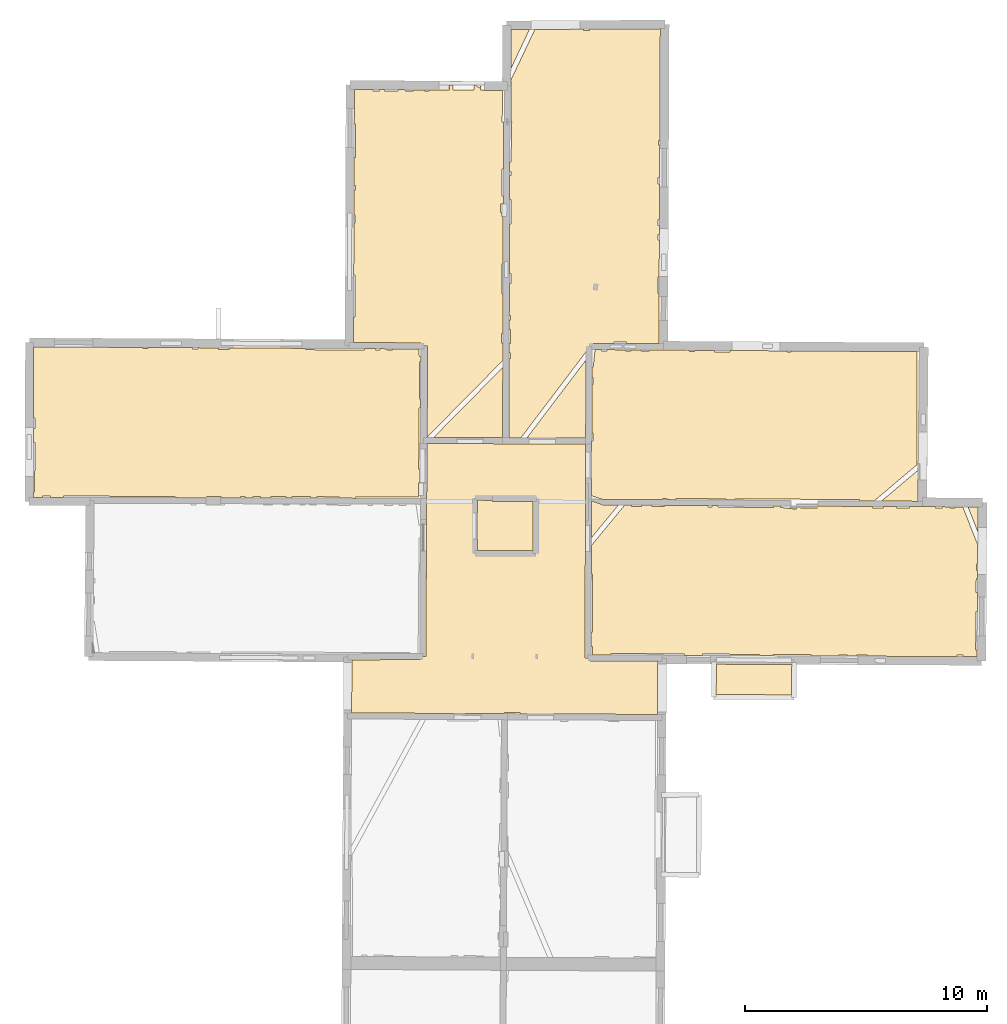
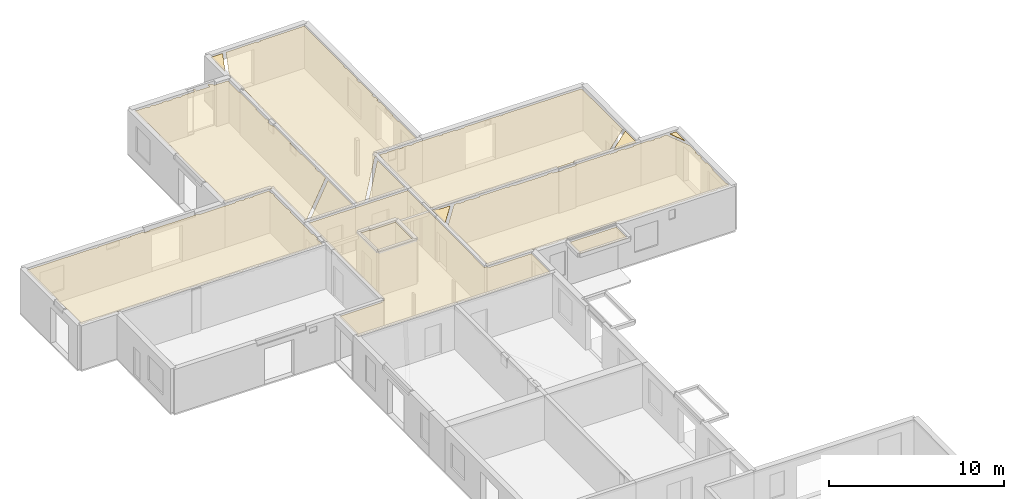
# One storey, part 13 of 15: 14 coverings.
"""IFC2X3 building model written with IfcOpenShell, lengths in metres."""

from ifc_helpers import new_model, entity, si_unit, converted_unit, derived_unit, direction, frame, origin, origin_with_axes, place, context, subcontext, project, spatial, polyline, outline, extrude, material, layer, layer_set, layer_usage, type_object, element, save


model = new_model("IFC2X3")

# Units and contexts
model_context = context("Model", 3, precision=1e-05, world=origin(), true_north=direction((0.0, 1.0)))
body_context = subcontext(model_context, "Body", "Model", "MODEL_VIEW")
ifc_project = project(units=[si_unit("LENGTHUNIT", "METRE"), si_unit("AREAUNIT", "SQUARE_METRE"), si_unit("VOLUMEUNIT", "CUBIC_METRE"), converted_unit("PLANEANGLEUNIT", "DEGREE", entity("IfcRatioMeasure", 0.0174532925199433), si_unit("PLANEANGLEUNIT", "RADIAN"), dimensions=[0, 0, 0, 0, 0, 0, 0]), si_unit("MASSUNIT", "GRAM", prefix="KILO"), derived_unit("MASSDENSITYUNIT", [(si_unit("MASSUNIT", "GRAM", prefix="KILO"), 1), (si_unit("LENGTHUNIT", "METRE"), -3)]), derived_unit("MOMENTOFINERTIAUNIT", [(si_unit("LENGTHUNIT", "METRE"), 4)]), si_unit("TIMEUNIT", "SECOND"), si_unit("FREQUENCYUNIT", "HERTZ"), si_unit("THERMODYNAMICTEMPERATUREUNIT", "DEGREE_CELSIUS"), derived_unit("THERMALTRANSMITTANCEUNIT", [(si_unit("MASSUNIT", "GRAM", prefix="KILO"), 1), (si_unit("THERMODYNAMICTEMPERATUREUNIT", "KELVIN"), -1), (si_unit("TIMEUNIT", "SECOND"), -3)]), derived_unit("VOLUMETRICFLOWRATEUNIT", [(si_unit("LENGTHUNIT", "METRE"), 3), (si_unit("TIMEUNIT", "SECOND"), -1)]), si_unit("ELECTRICCURRENTUNIT", "AMPERE"), si_unit("ELECTRICVOLTAGEUNIT", "VOLT"), si_unit("POWERUNIT", "WATT"), si_unit("FORCEUNIT", "NEWTON", prefix="KILO"), si_unit("ILLUMINANCEUNIT", "LUX"), si_unit("LUMINOUSFLUXUNIT", "LUMEN"), si_unit("LUMINOUSINTENSITYUNIT", "CANDELA"), derived_unit("USERDEFINED", [(si_unit("MASSUNIT", "GRAM", prefix="KILO"), -1), (si_unit("LENGTHUNIT", "METRE"), -2), (si_unit("TIMEUNIT", "SECOND"), 3), (si_unit("LUMINOUSFLUXUNIT", "LUMEN"), 1)]), derived_unit("LINEARVELOCITYUNIT", [(si_unit("LENGTHUNIT", "METRE"), 1), (si_unit("TIMEUNIT", "SECOND"), -1)]), si_unit("PRESSUREUNIT", "PASCAL"), derived_unit("USERDEFINED", [(si_unit("LENGTHUNIT", "METRE"), -2), (si_unit("MASSUNIT", "GRAM", prefix="KILO"), 1), (si_unit("TIMEUNIT", "SECOND"), -2)]), derived_unit("LINEARFORCEUNIT", [(si_unit("MASSUNIT", "GRAM", prefix="KILO"), 1), (si_unit("LENGTHUNIT", "METRE"), 1), (si_unit("TIMEUNIT", "SECOND"), -2), (si_unit("LENGTHUNIT", "METRE"), -1)]), derived_unit("PLANARFORCEUNIT", [(si_unit("MASSUNIT", "GRAM", prefix="KILO"), 1), (si_unit("LENGTHUNIT", "METRE"), 1), (si_unit("TIMEUNIT", "SECOND"), -2), (si_unit("LENGTHUNIT", "METRE"), -2)])], contexts=[model_context])

# Site, building, storey
placement = place(None, origin())
site = spatial("IfcSite", under=ifc_project, at=placement, CompositionType="ELEMENT")
building = spatial("IfcBuilding", under=site, at=placement, CompositionType="ELEMENT")
storey_placement = place(placement, frame((0.0, 0.0, 2.3807327747345)))
storey = spatial("IfcBuildingStorey", under=building, at=storey_placement, Name="Level 2", CompositionType="ELEMENT", Elevation=2.3807327747345)

# Coverings
ifc_material = material(Name="Covering default")
ifc_layer_1 = layer(ifc_material, 0.02)
ifc_layer_set_1 = layer_set([ifc_layer_1], Name="Covering : 20mm")
ifc_layer_usage_1 = layer_usage(ifc_layer_set_1, "AXIS3", "POSITIVE", 0.0)
covering_type_1 = type_object("IfcCoveringType", Name="Covering : 20mm", PredefinedType="CEILING")
covering_1_placement = place(placement, frame((0.0, 0.0, 5.31589412689209)))
element("IfcCovering", 1, at=covering_1_placement, inside=storey, type_object=covering_type_1, material=ifc_layer_usage_1, Name="Covering : 20mm", ObjectType="Covering : 20mm", PredefinedType="CEILING", context=body_context, shape_type="SweptSolid", body=[
    extrude(outline(polyline([(0.0212154388427734, 51.1030578613281), (2.85214328765869, 51.1116523742676), (2.85176181793213, 51.2374305725098), (3.07087993621826, 51.2362594604492), (3.12139987945557, 60.0334701538086), (6.24017238616943, 60.0231819152832), (9.67142772674561, 60.0118675231934), (9.64021587371826, 51.1887435913086), (9.84285259246826, 51.1880264282227), (9.84205532073975, 51.062816619873), (12.6475248336792, 51.0449867248535), (12.6377820968628, 48.8478355407715), (6.95900249481201, 48.876148223877), (6.95909786224365, 48.932804107666), (6.31617641448975, 48.9338722229004), (6.31608486175537, 48.8793563842773), (0.00825309753417969, 48.9108047485352), (0.0212154388427734, 51.1030578613281)])), origin_with_axes(), (0.0, 0.0, 1.0), 0.02),
])
ifc_layer_2 = layer(ifc_material, 0.02)
ifc_layer_set_2 = layer_set([ifc_layer_2], Name="Covering : 20mm")
ifc_layer_usage_2 = layer_usage(ifc_layer_set_2, "AXIS3", "POSITIVE", 0.0)
covering_type_2 = type_object("IfcCoveringType", Name="Covering : 20mm", PredefinedType="CEILING")
covering_2_placement = place(placement, frame((0.0, 0.0, 5.31589412689209)))
element("IfcCovering", 2, at=covering_2_placement, inside=storey, type_object=covering_type_2, material=ifc_layer_usage_2, Name="Covering : 20mm", ObjectType="Covering : 20mm", PredefinedType="CEILING", context=body_context, shape_type="SweptSolid", body=[
    extrude(outline(polyline([(15.0728063583374, 50.9225845336914), (18.1801872253418, 50.908634185791), (18.170539855957, 49.6549987792969), (15.0572061538696, 49.673583984375), (15.0728063583374, 50.9225845336914)])), origin_with_axes(), (0.0, 0.0, 1.0), 0.02),
])
ifc_layer_3 = layer(ifc_material, 0.02)
ifc_layer_set_3 = layer_set([ifc_layer_3], Name="Covering : 20mm")
ifc_layer_usage_3 = layer_usage(ifc_layer_set_3, "AXIS3", "POSITIVE", 0.0)
covering_type_3 = type_object("IfcCoveringType", Name="Covering : 20mm", PredefinedType="CEILING")
covering_3_placement = place(placement, frame((0.0, 0.0, 5.31589412689209)))
element("IfcCovering", 3, at=covering_3_placement, inside=storey, type_object=covering_type_3, material=ifc_layer_usage_3, Name="Covering : 20mm", ObjectType="Covering : 20mm", PredefinedType="CEILING", context=body_context, shape_type="SweptSolid", body=[
    extrude(outline(polyline([(9.89396572113037, 52.2481384277344), (9.94461345672607, 52.2478446960449), (9.95860576629639, 54.6478233337402), (9.90245532989502, 54.6481513977051), (9.90660762786865, 55.8220672607422), (11.2822408676147, 57.495304107666), (11.56334400177, 57.4933929443359), (11.5632467269897, 57.4351577758789), (11.9732465744019, 57.4344787597656), (11.9733400344849, 57.490608215332), (12.4133367538452, 57.4876174926758), (12.4132452011108, 57.4337463378906), (12.923243522644, 57.4328956604004), (12.9233293533325, 57.4841537475586), (14.7133131027222, 57.4719886779785), (14.7132253646851, 57.4199180603027), (14.8932256698608, 57.4196166992188), (14.8933115005493, 57.4707641601562), (15.1435708999634, 57.4690628051758), (15.1432085037231, 57.4092025756836), (17.4231910705566, 57.3954086303711), (17.4235420227051, 57.4535713195801), (17.7192878723145, 57.4515609741211), (17.7131881713867, 57.3949279785156), (18.3730697631836, 57.3238296508789), (18.3794288635254, 57.3828544616699), (19.2521591186523, 57.3787498474121), (19.2524909973145, 57.4487533569336), (21.5166397094727, 57.4381141662598), (21.5165405273438, 57.378604888916), (21.9631652832031, 57.377857208252), (21.963264465332, 57.4360122680664), (22.5032615661621, 57.4334754943848), (22.5031661987305, 57.3769607543945), (23.0331649780273, 57.3760757446289), (23.0332565307617, 57.4309844970703), (24.1150550842285, 57.4249267578125), (24.1131629943848, 57.3742828369141), (24.3931465148926, 57.3638153076172), (24.3953895568848, 57.4238052368164), (24.7132415771484, 57.422534942627), (24.7131462097168, 57.36328125), (24.9231452941895, 57.3629341125488), (24.9232444763184, 57.4216957092285), (25.2402076721191, 57.4204254150391), (25.8587760925293, 55.8549652099609), (25.854118347168, 55.0613822937012), (25.7993202209473, 55.0614738464355), (25.7988548278809, 54.7814750671387), (25.8524742126465, 54.7813835144043), (25.8506507873535, 54.4705009460449), (25.79833984375, 54.4714736938477), (25.7873573303223, 53.8814926147461), (25.8471908569336, 53.8803787231445), (25.8425559997559, 53.0910453796387), (25.7860450744629, 53.091495513916), (25.7734146118164, 51.5115127563477), (25.8332862854004, 51.5110359191895), (25.8316612243652, 51.2343254089355), (25.2429580688477, 51.2369689941406), (25.243049621582, 51.2923927307129), (25.0030479431152, 51.2927932739258), (25.0029563903809, 51.2380447387695), (21.3129806518555, 51.2546005249023), (21.3130722045898, 51.3089294433594), (20.8530693054199, 51.3096961975098), (20.8529815673828, 51.256664276123), (20.4729843139648, 51.2583694458008), (20.473072052002, 51.3103294372559), (20.1030731201172, 51.3109436035156), (20.1029891967773, 51.2600288391113), (18.9729957580566, 51.2650985717773), (18.9730911254883, 51.3228225708008), (17.4030914306641, 51.3254356384277), (17.403003692627, 51.2721405029297), (16.8427886962891, 51.2746543884277), (16.8430938720703, 51.3263664245605), (14.5031118392944, 51.340259552002), (14.5027856826782, 51.2851524353027), (13.7526750564575, 51.288516998291), (13.7531137466431, 51.3415069580078), (10.7231512069702, 51.3665466308594), (10.7226610183716, 51.3072280883789), (9.94305896759033, 51.3121795654297), (9.94361782073975, 51.6478424072266), (9.89184284210205, 51.6479301452637), (9.89396572113037, 52.2481384277344)])), origin_with_axes(), (0.0, 0.0, 1.0), 0.02),
])
ifc_layer_4 = layer(ifc_material, 0.02)
ifc_layer_set_4 = layer_set([ifc_layer_4], Name="Covering : 20mm")
ifc_layer_usage_4 = layer_usage(ifc_layer_set_4, "AXIS3", "POSITIVE", 0.0)
covering_type_4 = type_object("IfcCoveringType", Name="Covering : 20mm", PredefinedType="CEILING")
covering_4_placement = place(placement, frame((0.0, 0.0, 5.31589412689209)))
element("IfcCovering", 4, at=covering_4_placement, inside=storey, type_object=covering_type_4, material=ifc_layer_usage_4, Name="Covering : 20mm", ObjectType="Covering : 20mm", PredefinedType="CEILING", context=body_context, shape_type="SweptSolid", body=[
    extrude(outline(polyline([(5.2063684463501, 57.6921424865723), (5.81741428375244, 57.6910514831543), (5.81748104095459, 57.6421813964844), (7.49300479888916, 57.6444854736328), (7.48769283294678, 55.6214866638184), (5.20875644683838, 55.6242942810059), (5.2063684463501, 57.6921424865723)])), origin_with_axes(), (0.0, 0.0, 1.0), 0.02),
])
ifc_layer_5 = layer(ifc_material, 0.02)
ifc_layer_set_5 = layer_set([ifc_layer_5], Name="Covering : 20mm")
ifc_layer_usage_5 = layer_usage(ifc_layer_set_5, "AXIS3", "POSITIVE", 0.0)
covering_type_5 = type_object("IfcCoveringType", Name="Covering : 20mm", PredefinedType="CEILING")
covering_5_placement = place(placement, frame((0.0, 0.0, 5.31589412689209)))
element("IfcCovering", 5, at=covering_5_placement, inside=storey, type_object=covering_type_5, material=ifc_layer_usage_5, Name="Covering : 20mm", ObjectType="Covering : 20mm", PredefinedType="CEILING", context=body_context, shape_type="SweptSolid", body=[
    extrude(outline(polyline([(9.91312313079834, 57.6639175415039), (10.3684663772583, 57.5112915039062), (10.3683996200562, 57.5015144348145), (11.0247659683228, 57.4970550537109), (9.90772724151611, 56.138355255127), (9.91312313079834, 57.6639175415039)])), origin_with_axes(), (0.0, 0.0, 1.0), 0.02),
])
ifc_layer_6 = layer(ifc_material, 0.02)
ifc_layer_set_6 = layer_set([ifc_layer_6], Name="Covering : 20mm")
ifc_layer_usage_6 = layer_usage(ifc_layer_set_6, "AXIS3", "POSITIVE", 0.0)
covering_type_6 = type_object("IfcCoveringType", Name="Covering : 20mm", PredefinedType="CEILING")
covering_6_placement = place(placement, frame((0.0, 0.0, 5.31589412689209)))
element("IfcCovering", 6, at=covering_6_placement, inside=storey, type_object=covering_type_6, material=ifc_layer_usage_6, Name="Covering : 20mm", ObjectType="Covering : 20mm", PredefinedType="CEILING", context=body_context, shape_type="SweptSolid", body=[
    extrude(outline(polyline([(25.8619232177734, 56.3912353515625), (25.8679466247559, 57.4179153442383), (25.4555931091309, 57.4195671081543), (25.8619232177734, 56.3912353515625)])), origin_with_axes(), (0.0, 0.0, 1.0), 0.02),
])
ifc_layer_7 = layer(ifc_material, 0.02)
ifc_layer_set_7 = layer_set([ifc_layer_7], Name="Covering : 20mm")
ifc_layer_usage_7 = layer_usage(ifc_layer_set_7, "AXIS3", "POSITIVE", 0.0)
covering_type_7 = type_object("IfcCoveringType", Name="Covering : 20mm", PredefinedType="CEILING")
covering_7_placement = place(placement, frame((0.0, 0.0, 5.31589412689209)))
element("IfcCovering", 7, at=covering_7_placement, inside=storey, type_object=covering_type_7, material=ifc_layer_usage_7, Name="Covering : 20mm", ObjectType="Covering : 20mm", PredefinedType="CEILING", context=body_context, shape_type="SweptSolid", body=[
    extrude(outline(polyline([(21.8820304870605, 57.6563987731934), (23.3984146118164, 58.9378967285156), (23.3856048583984, 57.6493301391602), (21.8820304870605, 57.6563987731934)])), origin_with_axes(), (0.0, 0.0, 1.0), 0.02),
])
ifc_layer_8 = layer(ifc_material, 0.02)
ifc_layer_set_8 = layer_set([ifc_layer_8], Name="Covering : 20mm")
ifc_layer_usage_8 = layer_usage(ifc_layer_set_8, "AXIS3", "POSITIVE", 0.0)
covering_type_8 = type_object("IfcCoveringType", Name="Covering : 20mm", PredefinedType="CEILING")
covering_8_placement = place(placement, frame((0.0, 0.0, 5.31589412689209)))
element("IfcCovering", 8, at=covering_8_placement, inside=storey, type_object=covering_type_8, material=ifc_layer_usage_8, Name="Covering : 20mm", ObjectType="Covering : 20mm", PredefinedType="CEILING", context=body_context, shape_type="SweptSolid", body=[
    extrude(outline(polyline([(9.92142581939697, 60.0110092163086), (9.92142581939697, 60.0110092163086), (9.92186832427979, 60.1361045837402), (9.9777364730835, 60.1360130310059), (9.97828960418701, 60.4677963256836), (9.92304134368896, 60.467887878418), (9.93015193939209, 62.4778823852539), (9.9816312789917, 62.4777984619141), (9.98209667205811, 62.7577972412109), (9.93114376068115, 62.7578811645508), (9.93271923065186, 63.2031936645508), (9.98282909393311, 63.1977958679199), (10.0595026016235, 63.9094467163086), (10.3240118026733, 63.9081268310547), (10.3239278793335, 63.8572311401367), (10.5539274215698, 63.8568496704102), (10.5540113449097, 63.9069747924805), (11.3240041732788, 63.9031372070312), (11.3239088058472, 63.8455657958984), (11.5439100265503, 63.8451995849609), (11.5440034866333, 63.9020385742188), (11.9640016555786, 63.8999404907227), (11.9639081954956, 63.8445053100586), (12.3139066696167, 63.8439178466797), (12.3139982223511, 63.898193359375), (13.9539766311646, 63.8839492797852), (13.9538888931274, 63.8311920166016), (14.1738882064819, 63.8308258056641), (14.1739740371704, 63.8826065063477), (14.9839658737183, 63.8776550292969), (14.9838705062866, 63.8194808959961), (15.6338701248169, 63.8183975219727), (15.6339616775513, 63.8736877441406), (17.9739418029785, 63.8593902587891), (17.9738502502441, 63.8045043945312), (18.1438522338867, 63.8042221069336), (18.1439399719238, 63.8583526611328), (23.3437767028809, 63.8265762329102), (23.3466262817383, 59.1559867858887), (21.5738906860352, 57.657844543457), (20.9834060668945, 57.6606216430664), (20.9837341308594, 57.7194900512695), (15.8437719345093, 57.7480392456055), (15.8434743881226, 57.6943130493164), (15.4734373092651, 57.6968269348145), (15.4737730026245, 57.7486534118652), (13.3937940597534, 57.7621154785156), (13.3934621810913, 57.7109642028809), (13.0337114334106, 57.7134094238281), (13.0338106155396, 57.7727127075195), (12.8338117599487, 57.7730484008789), (12.8337144851685, 57.7147674560547), (10.3699617385864, 57.7315101623535), (10.3698949813843, 57.7217483520508), (9.91386890411377, 57.8746032714844), (9.92142581939697, 60.0110092163086)])), origin_with_axes(), (0.0, 0.0, 1.0), 0.02),
])
ifc_layer_9 = layer(ifc_material, 0.02)
ifc_layer_set_9 = layer_set([ifc_layer_9], Name="Covering : 20mm")
ifc_layer_usage_9 = layer_usage(ifc_layer_set_9, "AXIS3", "POSITIVE", 0.0)
covering_type_9 = type_object("IfcCoveringType", Name="Covering : 20mm", PredefinedType="CEILING")
covering_9_placement = place(placement, frame((0.0, 0.0, 5.31589412689209)))
element("IfcCovering", 9, at=covering_9_placement, inside=storey, type_object=covering_type_9, material=ifc_layer_usage_9, Name="Covering : 20mm", ObjectType="Covering : 20mm", PredefinedType="CEILING", context=body_context, shape_type="SweptSolid", body=[
    extrude(outline(polyline([(-13.1334638595581, 58.0262413024902), (-13.0758037567139, 58.0261459350586), (-13.0723781585693, 60.0861434936523), (-13.1308546066284, 60.086238861084), (-13.130145072937, 60.646240234375), (-13.0714473724365, 60.6461410522461), (-13.0706977844238, 61.0961380004883), (-13.1295747756958, 61.0962371826172), (-13.125864982605, 64.0254592895508), (-8.59586238861084, 64.0006713867188), (-8.59594821929932, 63.9486999511719), (-8.40594673156738, 63.9483871459961), (-8.40586280822754, 63.9996337890625), (-6.56587743759155, 63.9895629882812), (-6.56596851348877, 63.9353256225586), (-6.33596515655518, 63.934944152832), (-6.33587551116943, 63.9883041381836), (-5.49621200561523, 63.9837112426758), (-5.49631214141846, 63.9235534667969), (-5.04598522186279, 63.9227981567383), (-5.0458869934082, 63.9812469482422), (-1.89568138122559, 63.9640045166016), (-1.89600658416748, 63.9075546264648), (0.543974876403809, 63.8935012817383), (0.544303894042969, 63.9506072998047), (0.984066009521484, 63.9484634399414), (0.983972549438477, 63.8927688598633), (1.18397235870361, 63.8924331665039), (1.1840648651123, 63.9474868774414), (1.47406101226807, 63.9460754394531), (1.47397136688232, 63.8919525146484), (1.70397281646729, 63.8915710449219), (1.70406150817871, 63.9449615478516), (2.77944469451904, 63.9397277832031), (2.80352115631104, 63.6197357177734), (2.86352825164795, 63.6242523193359), (2.86214351654053, 63.3996353149414), (2.80315494537354, 63.3997344970703), (2.80062580108643, 61.8797378540039), (2.85277462005615, 61.8796501159668), (2.85043048858643, 61.4992561340332), (2.79999446868896, 61.4997406005859), (2.775803565979, 58.9797744750977), (2.8348970413208, 58.9792060852051), (2.83139705657959, 58.4115257263184), (2.77416324615479, 58.4111175537109), (2.7783670425415, 57.8197708129883), (0.163876533508301, 57.8241195678711), (0.163793563842773, 57.7739868164062), (-0.486203193664551, 57.7758445739746), (-0.486104965209961, 57.8352012634277), (-1.41610431671143, 57.8367462158203), (-1.41620063781738, 57.7785034179688), (-1.68620014190674, 57.7792739868164), (-1.68610382080078, 57.8371963500977), (-2.45610332489014, 57.8384780883789), (-2.45619773864746, 57.7814750671387), (-2.69619750976562, 57.7821578979492), (-2.6961030960083, 57.8388748168945), (-3.32610130310059, 57.8399276733398), (-3.32619476318359, 57.7839584350586), (-3.74619388580322, 57.7851600646973), (-3.74610042572021, 57.8406219482422), (-4.0560998916626, 57.8411407470703), (-4.05619239807129, 57.7860450744629), (-4.39618968963623, 57.7870178222656), (-4.39609909057617, 57.8417053222656), (-4.57609939575195, 57.8420028686523), (-4.57618999481201, 57.7875289916992), (-5.37618732452393, 57.7898178100586), (-5.37609767913818, 57.843334197998), (-5.98609924316406, 57.8443489074707), (-5.98618698120117, 57.791561126709), (-7.27629089355469, 57.7952461242676), (-7.27609443664551, 57.8464965820312), (-11.8960742950439, 57.8641815185547), (-11.8962965011597, 57.8061103820801), (-12.4261655807495, 57.8092269897461), (-12.4260730743408, 57.865062713623), (-12.746072769165, 57.865592956543), (-12.7461633682251, 57.811107635498), (-13.1337337493896, 57.8133850097656), (-13.1334638595581, 58.0262413024902)])), origin_with_axes(), (0.0, 0.0, 1.0), 0.02),
])
ifc_layer_10 = layer(ifc_material, 0.02)
ifc_layer_set_10 = layer_set([ifc_layer_10], Name="Covering : 20mm")
ifc_layer_usage_10 = layer_usage(ifc_layer_set_10, "AXIS3", "POSITIVE", 0.0)
covering_type_10 = type_object("IfcCoveringType", Name="Covering : 20mm", PredefinedType="CEILING")
covering_10_placement = place(placement, frame((0.0, 0.0, 5.31589412689209)))
element("IfcCovering", 10, at=covering_10_placement, inside=storey, type_object=covering_type_10, material=ifc_layer_usage_10, Name="Covering : 20mm", ObjectType="Covering : 20mm", PredefinedType="CEILING", context=body_context, shape_type="SweptSolid", body=[
    extrude(outline(polyline([(7.24894046783447, 60.2698593139648), (9.68370723724365, 63.4831466674805), (9.67231273651123, 60.2618675231934), (7.24894046783447, 60.2698593139648)])), origin_with_axes(), (0.0, 0.0, 1.0), 0.02),
])
ifc_layer_11 = layer(ifc_material, 0.02)
ifc_layer_set_11 = layer_set([ifc_layer_11], Name="Covering : 20mm")
ifc_layer_usage_11 = layer_usage(ifc_layer_set_11, "AXIS3", "POSITIVE", 0.0)
covering_type_11 = type_object("IfcCoveringType", Name="Covering : 20mm", PredefinedType="CEILING")
covering_11_placement = place(placement, frame((0.0, 0.0, 5.31589412689209)))
element("IfcCovering", 11, at=covering_11_placement, inside=storey, type_object=covering_type_11, material=ifc_layer_usage_11, Name="Covering : 20mm", ObjectType="Covering : 20mm", PredefinedType="CEILING", context=body_context, shape_type="SweptSolid", body=[
    extrude(outline(polyline([(6.51041889190674, 63.5354499816895), (6.56338596343994, 63.5353622436523), (6.56376552581787, 63.7634811401367), (6.51108074188232, 63.7635726928711), (6.5122709274292, 64.1735763549805), (6.56444835662842, 64.1734848022461), (6.56539440155029, 64.7434844970703), (6.51392650604248, 64.7435684204102), (6.51505756378174, 65.1335678100586), (6.56604480743408, 65.1334838867188), (6.56634426116943, 65.3134841918945), (6.51558017730713, 65.3135681152344), (6.51944065093994, 66.6435623168945), (6.5785551071167, 66.6434631347656), (6.57922267913818, 67.0434646606445), (6.52060222625732, 67.0435638427734), (6.52658176422119, 69.1035461425781), (6.58264827728271, 69.1034545898438), (6.58432865142822, 70.1134643554688), (6.52951335906982, 70.1135559082031), (6.53238773345947, 71.1035461425781), (6.58597469329834, 71.1034545898438), (6.58624172210693, 71.2634582519531), (6.53285121917725, 71.2635498046875), (6.53398609161377, 71.6545028686523), (6.58689022064209, 71.6534576416016), (6.61974811553955, 73.3090896606445), (6.59163570404053, 73.3096466064453), (6.5914831161499, 74.9943695068359), (6.57648754119873, 74.9943695068359), (6.57659244537354, 75.02490234375), (7.57321453094482, 77.1295394897461), (9.57602024078369, 77.1407318115234), (9.57593441009521, 77.0884857177734), (9.83593273162842, 77.0880584716797), (9.83602237701416, 77.1421813964844), (12.7516660690308, 77.1584777832031), (12.7309503555298, 72.5432281494141), (12.6783781051636, 72.5433197021484), (12.6780614852905, 72.3533248901367), (12.7300977706909, 72.3532409667969), (12.724081993103, 71.0132446289062), (12.6658353805542, 71.0133438110352), (12.6654005050659, 70.7533416748047), (12.7229166030884, 70.7532424926758), (12.7162733078003, 69.2732543945312), (12.6629400253296, 69.2733459472656), (12.6625394821167, 69.0333480834961), (12.7151956558228, 69.0332565307617), (12.7135801315308, 68.6732635498047), (12.661940574646, 68.6733474731445), (12.6615438461304, 68.433349609375), (12.7125024795532, 68.4332656860352), (12.7056798934937, 66.9132766723633), (12.6490125656128, 66.9133682250977), (12.6478662490845, 66.2233657836914), (12.702582359314, 66.223274230957), (12.693305015564, 64.1563034057617), (11.3644361495972, 64.1629333496094), (11.3645238876343, 64.2154998779297), (10.8345251083374, 64.2163848876953), (10.8344411849976, 64.1655807495117), (9.98070812225342, 64.1698379516602), (9.980055809021, 64.0391159057617), (9.87355327606201, 64.0505905151367), (9.84818172454834, 63.8151092529297), (9.80989551544189, 63.8152465820312), (9.73018169403076, 63.8756484985352), (6.99863719940186, 60.2706832885742), (6.50094699859619, 60.2723236083984), (6.51041889190674, 63.5354499816895)])), origin_with_axes(), (0.0, 0.0, 1.0), 0.02),
])
ifc_layer_12 = layer(ifc_material, 0.02)
ifc_layer_set_12 = layer_set([ifc_layer_12], Name="Covering : 20mm")
ifc_layer_usage_12 = layer_usage(ifc_layer_set_12, "AXIS3", "POSITIVE", 0.0)
covering_type_12 = type_object("IfcCoveringType", Name="Covering : 20mm", PredefinedType="CEILING")
covering_12_placement = place(placement, frame((0.0, 0.0, 5.31589412689209)))
element("IfcCovering", 12, at=covering_12_placement, inside=storey, type_object=covering_type_12, material=ifc_layer_usage_12, Name="Covering : 20mm", ObjectType="Covering : 20mm", PredefinedType="CEILING", context=body_context, shape_type="SweptSolid", body=[
    extrude(outline(polyline([(3.39341831207275, 60.2825775146484), (6.24937534332275, 63.1763305664062), (6.24094867706299, 60.2731819152832), (3.39341831207275, 60.2825775146484)])), origin_with_axes(), (0.0, 0.0, 1.0), 0.02),
])
ifc_layer_13 = layer(ifc_material, 0.02)
ifc_layer_set_13 = layer_set([ifc_layer_13], Name="Covering : 20mm")
ifc_layer_usage_13 = layer_usage(ifc_layer_set_13, "AXIS3", "POSITIVE", 0.0)
covering_type_13 = type_object("IfcCoveringType", Name="Covering : 20mm", PredefinedType="CEILING")
covering_13_placement = place(placement, frame((0.0, 0.0, 5.31589412689209)))
element("IfcCovering", 13, at=covering_13_placement, inside=storey, type_object=covering_type_13, material=ifc_layer_usage_13, Name="Covering : 20mm", ObjectType="Covering : 20mm", PredefinedType="CEILING", context=body_context, shape_type="SweptSolid", body=[
    extrude(outline(polyline([(0.0884180068969727, 65.2642593383789), (0.146252632141113, 65.26416015625), (0.149113655090332, 66.9841613769531), (0.094355583190918, 66.9842529296875), (0.101778030395508, 69.1342391967773), (0.152689933776855, 69.1341552734375), (0.153238296508789, 69.4641571044922), (0.102917671203613, 69.464241027832), (0.106472969055176, 70.4942398071289), (0.164952278137207, 70.494140625), (0.165284156799316, 70.6941375732422), (0.107163429260254, 70.6942367553711), (0.111133575439453, 71.8442230224609), (0.167197227478027, 71.8441314697266), (0.169493675231934, 73.2241363525391), (0.115897178649902, 73.2242279052734), (0.120851516723633, 74.6591110229492), (0.891868591308594, 74.6519088745117), (0.891772270202637, 74.5929260253906), (1.16177082061768, 74.5924835205078), (1.16186428070068, 74.6493835449219), (1.37186336517334, 74.6474227905273), (1.37177181243896, 74.5921325683594), (1.93176937103271, 74.5912017822266), (1.93185424804688, 74.6421890258789), (2.23185062408447, 74.6393814086914), (2.23175239562988, 74.5807037353516), (2.56175327301025, 74.5801544189453), (2.56184673309326, 74.6362991333008), (3.01183986663818, 74.6320953369141), (3.01175212860107, 74.5794067382812), (3.21175289154053, 74.5790710449219), (3.211838722229, 74.6302261352539), (3.62147045135498, 74.6263961791992), (3.62155818939209, 74.6358261108398), (4.0394983291626, 74.6338577270508), (4.04047107696533, 74.8408432006836), (4.19797801971436, 74.8401107788086), (4.19559955596924, 74.6300659179688), (5.06054401397705, 74.6202774047852), (5.06298732757568, 74.836051940918), (5.09751605987549, 74.8358917236328), (5.28620433807373, 74.715950012207), (5.33984279632568, 74.8003311157227), (5.33816051483154, 74.6203536987305), (6.24257946014404, 74.6119079589844), (6.22310543060303, 73.3132019042969), (6.27879810333252, 73.312370300293), (6.27314281463623, 71.3639831542969), (6.21640872955322, 71.3640747070312), (6.21454524993896, 70.2440719604492), (6.26989078521729, 70.2439804077148), (6.26896381378174, 69.9244079589844), (6.21365642547607, 69.9245376586914), (6.21363162994385, 69.9140777587891), (6.15399646759033, 69.914176940918), (6.15342998504639, 69.5741729736328), (6.21280956268311, 69.5740737915039), (6.21241092681885, 69.409538269043), (6.26746845245361, 69.4094085693359), (6.26179218292236, 67.4539947509766), (6.20990467071533, 67.4540786743164), (6.20784282684326, 66.2140808105469), (6.25819301605225, 66.213996887207), (6.25343227386475, 64.5739974975586), (6.19511318206787, 64.5740966796875), (6.19446468353271, 64.1840972900391), (6.25230121612549, 64.1839981079102), (6.25020503997803, 63.4618873596191), (3.12300205230713, 60.2933006286621), (3.14623737335205, 64.062744140625), (2.97067165374756, 64.0638275146484), (2.97007274627686, 64.0717849731445), (2.87035465240479, 64.0642852783203), (2.87096309661865, 64.1892776489258), (0.0847539901733398, 64.2028350830078), (0.0884180068969727, 65.2642593383789)])), origin_with_axes(), (0.0, 0.0, 1.0), 0.02),
])
ifc_layer_14 = layer(ifc_material, 0.02)
ifc_layer_set_14 = layer_set([ifc_layer_14], Name="Covering : 20mm")
ifc_layer_usage_14 = layer_usage(ifc_layer_set_14, "AXIS3", "POSITIVE", 0.0)
covering_type_14 = type_object("IfcCoveringType", Name="Covering : 20mm", PredefinedType="CEILING")
covering_14_placement = place(placement, frame((0.0, 0.0, 5.31589412689209)))
element("IfcCovering", 14, at=covering_14_placement, inside=storey, type_object=covering_type_14, material=ifc_layer_usage_14, Name="Covering : 20mm", ObjectType="Covering : 20mm", PredefinedType="CEILING", context=body_context, shape_type="SweptSolid", body=[
    extrude(outline(polyline([(6.58379650115967, 77.1240081787109), (7.35133838653564, 77.1282958984375), (6.57820796966553, 75.4956283569336), (6.58379650115967, 77.1240081787109)])), origin_with_axes(), (0.0, 0.0, 1.0), 0.02),
])

save(model, "model.ifc")
